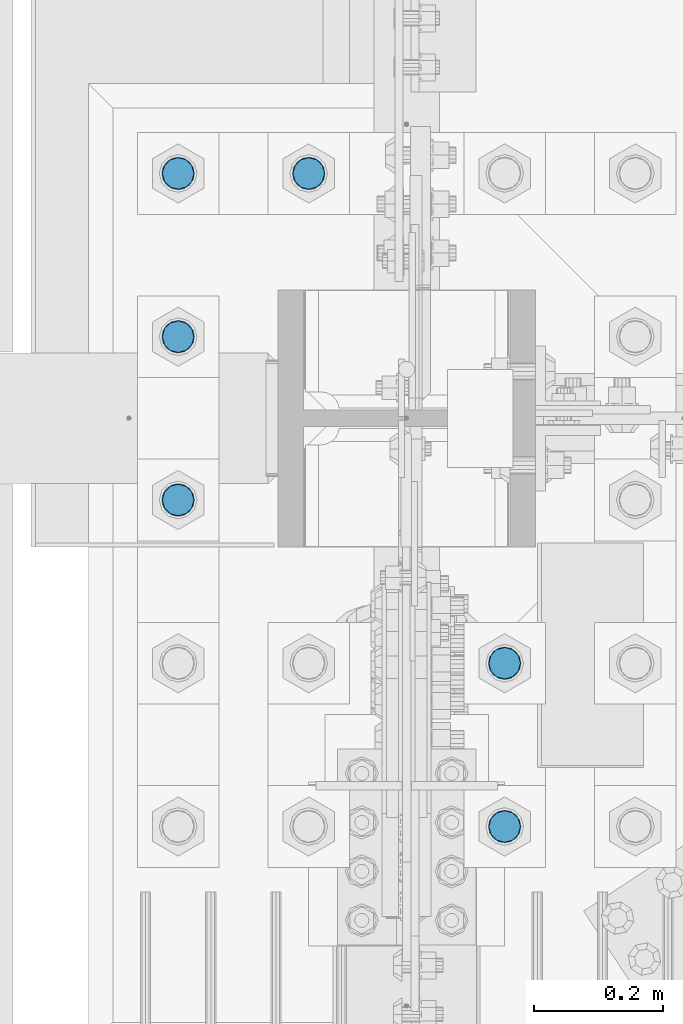
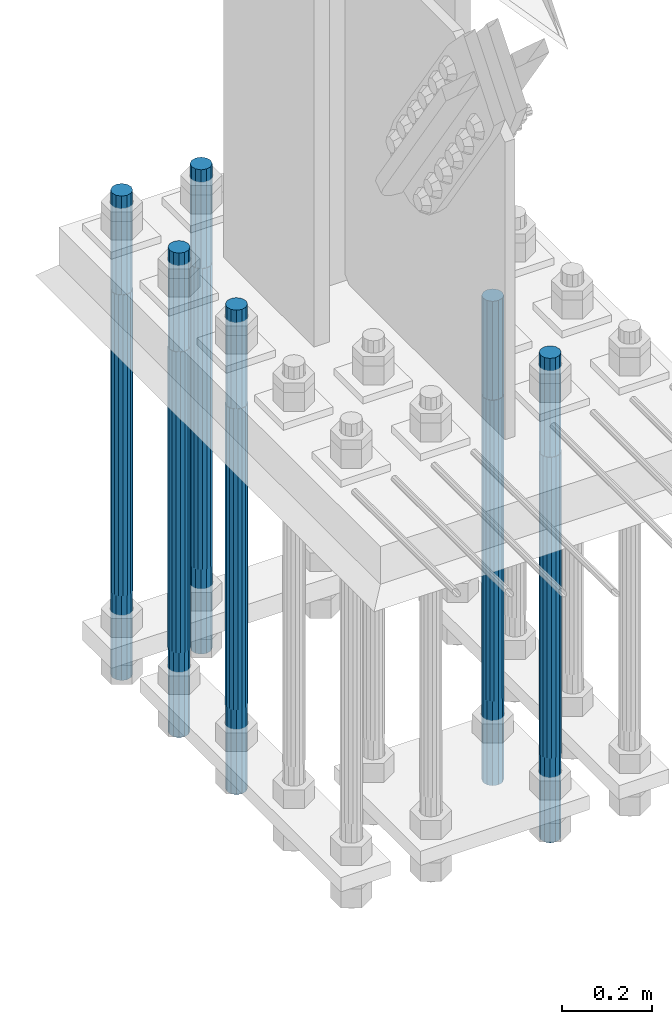
# One storey, part 1330 of 3843: 6 columns, 1 element without a shape of its own.
"""IFC2X3 building model written with IfcOpenShell, lengths in millimetres."""

from ifc_helpers import new_model, si_unit, frame, origin_with_axes, place, context, subcontext, project, spatial, faceted_brep, material, type_object, element, aggregate, save


model = new_model("IFC2X3")

# Units and contexts
model_context = context("Model", 3, precision=1e-05, world=origin_with_axes())
body_context = subcontext(model_context, "Body", "Model", "MODEL_VIEW")
ifc_project = project(units=[si_unit("LENGTHUNIT", "METRE", prefix="MILLI"), si_unit("AREAUNIT", "SQUARE_METRE"), si_unit("VOLUMEUNIT", "CUBIC_METRE"), si_unit("MASSUNIT", "GRAM", prefix="KILO"), si_unit("TIMEUNIT", "SECOND"), si_unit("PLANEANGLEUNIT", "RADIAN"), si_unit("SOLIDANGLEUNIT", "STERADIAN"), si_unit("THERMODYNAMICTEMPERATUREUNIT", "DEGREE_CELSIUS"), si_unit("LUMINOUSINTENSITYUNIT", "LUMEN")], contexts=[model_context])

# Site, building, storey
site_placement = place(None, origin_with_axes())
site = spatial("IfcSite", under=ifc_project, at=site_placement, CompositionType="ELEMENT")
building_placement = place(site_placement, origin_with_axes())
building = spatial("IfcBuilding", under=site, at=building_placement, Name="Undefined", CompositionType="ELEMENT")
storey_placement = place(building_placement, origin_with_axes())
storey = spatial("IfcBuildingStorey", under=building, at=storey_placement, Name="Undefined", CompositionType="ELEMENT", Elevation=0.0)

# Assembly, columns
assembly_placement = place(storey_placement, origin_with_axes())
assembly = element("IfcElementAssembly", 1, at=assembly_placement, inside=storey, Name="TEMPLATE", AssemblyPlace="NOTDEFINED", PredefinedType="RIGID_FRAME")
ifc_material = material(Name="Undefined/F1554-GR.55")
column_type = type_object("IfcColumnType", PredefinedType="NOTDEFINED")
column_1_placement = place(assembly_placement, frame((36728.4, 58280.3, 30022.8), z_axis=(1.0, 0.0, 0.0), x_axis=(0.0, 0.0, -1.0)))
column_1 = element("IfcColumn", 2, at=column_1_placement, type_object=column_type, material=ifc_material, Name="ANCHOR_ROD", context=body_context, shape_type="Brep", body=[
    faceted_brep([(-266.700000000001, -21.2176223927236, 12.25), (-266.700000000001, -12.25, 21.2176223927163), (-266.700000000001, 0.0, 24.5), (-266.700000000001, 12.25, 21.2176223927163), (-266.700000000001, 21.2176223927236, 12.25), (-266.700000000001, 24.5, 0.0), (-266.700000000001, 21.2176223927236, -12.25), (-266.700000000001, 12.25, -21.2176223927163), (-266.700000000001, 0.0, -24.5), (-266.700000000001, -12.25, -21.2176223927163), (-266.700000000001, -21.2176223927236, -12.25), (-266.700000000001, -24.5, 0.0), (0.0, 24.5000000000146, 0.0), (0.0, 21.2176223927381, -12.25), (0.0, 12.2500000000146, -21.2176223927163), (0.0, 1.45519152283669e-11, -24.5), (0.0, -12.2499999999854, -21.2176223927163), (0.0, -21.217622392709, -12.25), (0.0, -24.4999999999854, 0.0), (0.0, -21.217622392709, 12.25), (0.0, -12.2499999999854, 21.2176223927163), (0.0, 1.45519152283669e-11, 24.5), (0.0, 12.2500000000146, 21.2176223927163), (0.0, 21.2176223927381, 12.25), (0.0, -23.4665401257807, 9.72015918207035), (0.0, -17.9605122421344, 17.9605122421417), (0.0, -9.72015918207762, 23.466540125788), (0.0, 0.0, 25.4000000000015), (0.0, 9.72015918207762, 23.466540125788), (0.0, 17.9605122421344, 17.9605122421417), (0.0, 23.4665401257807, 9.72015918207035), (0.0, 25.3999996185303, 0.0), (0.0, 23.4665401257807, -9.72015918207035), (0.0, 17.9605122421344, -17.9605122421417), (0.0, 9.72015918207762, -23.466540125788), (0.0, 0.0, -25.4000000000015), (0.0, -9.72015918207762, -23.466540125788), (0.0, -17.9605122421344, -17.9605122421417), (0.0, -23.4665401257807, -9.72015918207035), (0.0, -25.3999996185303, 0.0), (812.799999999999, -25.4000000000015, 0.0), (812.799999999999, -23.466540125788, 9.72015918207398), (812.799999999999, -17.9605122421417, 17.9605122421381), (812.799999999999, -9.72015918207035, 23.466540125788), (812.799999999999, 0.0, 25.4000000000015), (812.799999999999, 9.72015918207035, 23.466540125788), (812.799999999999, 17.9605122421417, 17.9605122421381), (812.799999999999, 23.466540125788, 9.72015918207398), (812.799999999999, 25.4000000000015, 0.0), (812.799999999999, 23.466540125788, -9.72015918207398), (812.799999999999, 17.9605122421417, -17.9605122421381), (812.799999999999, 9.72015918207035, -23.466540125788), (812.799999999999, 0.0, -25.4000000000015), (812.799999999999, -9.72015918207035, -23.466540125788), (812.799999999999, -17.9605122421417, -17.9605122421381), (812.799999999999, -23.466540125788, -9.72015918207398), (812.799999999999, -12.25, 21.2176223927199), (812.799999999999, 0.0, 24.5), (812.799999999999, 12.25, 21.2176223927199), (812.799999999999, 21.2176223927163, 12.25), (812.799999999999, 24.5, 0.0), (812.799999999999, 21.2176223927163, -12.25), (812.799999999999, 12.25, -21.2176223927199), (812.799999999999, 0.0, -24.5), (812.799999999999, -12.25, -21.2176223927199), (812.799999999999, -21.2176223927163, -12.25), (812.799999999999, -24.5, 0.0), (812.799999999999, -21.2176223927163, 12.25), (1041.4, -12.25, -21.2176223927199), (1041.4, 0.0, -24.5), (1041.4, 12.25, -21.2176223927199), (1041.4, 21.2176223927163, -12.25), (1041.4, 24.5, 0.0), (1041.4, 21.2176223927163, 12.25), (1041.4, 12.25, 21.2176223927199), (1041.4, 0.0, 24.5), (1041.4, -12.25, 21.2176223927199), (1041.4, -21.2176223927163, 12.25), (1041.4, -24.5, 0.0), (1041.4, -21.2176223927163, -12.25)], [[[0, 1, 2, 3, 4, 5, 6, 7, 8, 9, 10, 11]], [[6, 5, 12, 13]], [[7, 6, 13, 14]], [[8, 7, 14, 15]], [[9, 8, 15, 16]], [[10, 9, 16, 17]], [[11, 10, 17, 18]], [[0, 11, 18, 19]], [[1, 0, 19, 20]], [[2, 1, 20, 21]], [[3, 2, 21, 22]], [[4, 3, 22, 23]], [[5, 4, 23, 12]], [[24, 25, 26, 27, 28, 29, 30, 31, 32, 33, 34, 35, 36, 37, 38, 39], [22, 21, 20, 19, 18, 17, 16, 15, 14, 13, 12, 23]], [[24, 39, 40, 41]], [[25, 24, 41, 42]], [[26, 25, 42, 43]], [[27, 26, 43, 44]], [[28, 27, 44, 45]], [[29, 28, 45, 46]], [[30, 29, 46, 47]], [[31, 30, 47, 48]], [[32, 31, 48, 49]], [[33, 32, 49, 50]], [[34, 33, 50, 51]], [[35, 34, 51, 52]], [[36, 35, 52, 53]], [[37, 36, 53, 54]], [[38, 37, 54, 55]], [[39, 38, 55, 40]], [[54, 53, 52, 51, 50, 49, 48, 47, 46, 45, 44, 43, 42, 41, 40, 55], [56, 57, 58, 59, 60, 61, 62, 63, 64, 65, 66, 67]], [[68, 69, 70, 71, 72, 73, 74, 75, 76, 77, 78, 79]], [[76, 75, 57, 56]], [[77, 76, 56, 67]], [[78, 77, 67, 66]], [[79, 78, 66, 65]], [[68, 79, 65, 64]], [[69, 68, 64, 63]], [[70, 69, 63, 62]], [[71, 70, 62, 61]], [[72, 71, 61, 60]], [[73, 72, 60, 59]], [[74, 73, 59, 58]], [[75, 74, 58, 57]]]),
])
column_2_placement = place(assembly_placement, frame((36728.4, 58534.3, 30022.8), z_axis=(1.0, 0.0, 0.0), x_axis=(0.0, 0.0, -1.0)))
column_2 = element("IfcColumn", 3, at=column_2_placement, type_object=column_type, material=ifc_material, Name="ANCHOR_ROD", context=body_context, shape_type="Brep", body=[
    faceted_brep([(-266.700000000001, -21.2176223927236, 12.25), (-266.700000000001, -12.25, 21.2176223927163), (-266.700000000001, 0.0, 24.5), (-266.700000000001, 12.25, 21.2176223927163), (-266.700000000001, 21.2176223927236, 12.25), (-266.700000000001, 24.5, 0.0), (-266.700000000001, 21.2176223927236, -12.25), (-266.700000000001, 12.25, -21.2176223927163), (-266.700000000001, 0.0, -24.5), (-266.700000000001, -12.25, -21.2176223927163), (-266.700000000001, -21.2176223927236, -12.25), (-266.700000000001, -24.5, 0.0), (0.0, 24.5000000000146, 0.0), (0.0, 21.2176223927381, -12.25), (0.0, 12.2500000000146, -21.2176223927163), (0.0, 1.45519152283669e-11, -24.5), (0.0, -12.2499999999854, -21.2176223927163), (0.0, -21.217622392709, -12.25), (0.0, -24.4999999999854, 0.0), (0.0, -21.217622392709, 12.25), (0.0, -12.2499999999854, 21.2176223927163), (0.0, 1.45519152283669e-11, 24.5), (0.0, 12.2500000000146, 21.2176223927163), (0.0, 21.2176223927381, 12.25), (0.0, -23.4665401257807, 9.72015918207035), (0.0, -17.9605122421344, 17.9605122421417), (0.0, -9.72015918207762, 23.466540125788), (0.0, 0.0, 25.4000000000015), (0.0, 9.72015918207762, 23.466540125788), (0.0, 17.9605122421344, 17.9605122421417), (0.0, 23.4665401257807, 9.72015918207035), (0.0, 25.3999996185303, 0.0), (0.0, 23.4665401257807, -9.72015918207035), (0.0, 17.9605122421344, -17.9605122421417), (0.0, 9.72015918207762, -23.466540125788), (0.0, 0.0, -25.4000000000015), (0.0, -9.72015918207762, -23.466540125788), (0.0, -17.9605122421344, -17.9605122421417), (0.0, -23.4665401257807, -9.72015918207035), (0.0, -25.3999996185303, 0.0), (812.799999999999, -25.4000000000015, 0.0), (812.799999999999, -23.466540125788, 9.72015918207398), (812.799999999999, -17.9605122421417, 17.9605122421381), (812.799999999999, -9.72015918207035, 23.466540125788), (812.799999999999, 0.0, 25.4000000000015), (812.799999999999, 9.72015918207035, 23.466540125788), (812.799999999999, 17.9605122421417, 17.9605122421381), (812.799999999999, 23.466540125788, 9.72015918207398), (812.799999999999, 25.4000000000015, 0.0), (812.799999999999, 23.466540125788, -9.72015918207398), (812.799999999999, 17.9605122421417, -17.9605122421381), (812.799999999999, 9.72015918207035, -23.466540125788), (812.799999999999, 0.0, -25.4000000000015), (812.799999999999, -9.72015918207035, -23.466540125788), (812.799999999999, -17.9605122421417, -17.9605122421381), (812.799999999999, -23.466540125788, -9.72015918207398), (812.799999999999, -12.25, 21.2176223927199), (812.799999999999, 0.0, 24.5), (812.799999999999, 12.25, 21.2176223927199), (812.799999999999, 21.2176223927163, 12.25), (812.799999999999, 24.5, 0.0), (812.799999999999, 21.2176223927163, -12.25), (812.799999999999, 12.25, -21.2176223927199), (812.799999999999, 0.0, -24.5), (812.799999999999, -12.25, -21.2176223927199), (812.799999999999, -21.2176223927163, -12.25), (812.799999999999, -24.5, 0.0), (812.799999999999, -21.2176223927163, 12.25), (1041.4, -12.25, -21.2176223927199), (1041.4, 0.0, -24.5), (1041.4, 12.25, -21.2176223927199), (1041.4, 21.2176223927163, -12.25), (1041.4, 24.5, 0.0), (1041.4, 21.2176223927163, 12.25), (1041.4, 12.25, 21.2176223927199), (1041.4, 0.0, 24.5), (1041.4, -12.25, 21.2176223927199), (1041.4, -21.2176223927163, 12.25), (1041.4, -24.5, 0.0), (1041.4, -21.2176223927163, -12.25)], [[[0, 1, 2, 3, 4, 5, 6, 7, 8, 9, 10, 11]], [[6, 5, 12, 13]], [[7, 6, 13, 14]], [[8, 7, 14, 15]], [[9, 8, 15, 16]], [[10, 9, 16, 17]], [[11, 10, 17, 18]], [[0, 11, 18, 19]], [[1, 0, 19, 20]], [[2, 1, 20, 21]], [[3, 2, 21, 22]], [[4, 3, 22, 23]], [[5, 4, 23, 12]], [[24, 25, 26, 27, 28, 29, 30, 31, 32, 33, 34, 35, 36, 37, 38, 39], [22, 21, 20, 19, 18, 17, 16, 15, 14, 13, 12, 23]], [[24, 39, 40, 41]], [[25, 24, 41, 42]], [[26, 25, 42, 43]], [[27, 26, 43, 44]], [[28, 27, 44, 45]], [[29, 28, 45, 46]], [[30, 29, 46, 47]], [[31, 30, 47, 48]], [[32, 31, 48, 49]], [[33, 32, 49, 50]], [[34, 33, 50, 51]], [[35, 34, 51, 52]], [[36, 35, 52, 53]], [[37, 36, 53, 54]], [[38, 37, 54, 55]], [[39, 38, 55, 40]], [[54, 53, 52, 51, 50, 49, 48, 47, 46, 45, 44, 43, 42, 41, 40, 55], [56, 57, 58, 59, 60, 61, 62, 63, 64, 65, 66, 67]], [[68, 69, 70, 71, 72, 73, 74, 75, 76, 77, 78, 79]], [[76, 75, 57, 56]], [[77, 76, 56, 67]], [[78, 77, 67, 66]], [[79, 78, 66, 65]], [[68, 79, 65, 64]], [[69, 68, 64, 63]], [[70, 69, 63, 62]], [[71, 70, 62, 61]], [[72, 71, 61, 60]], [[73, 72, 60, 59]], [[74, 73, 59, 58]], [[75, 74, 58, 57]]]),
])
column_3_placement = place(assembly_placement, frame((36423.6, 59296.3, 30022.8), z_axis=(-1.0, 0.0, 0.0), x_axis=(0.0, 0.0, -1.0)))
column_3 = element("IfcColumn", 4, at=column_3_placement, type_object=column_type, material=ifc_material, Name="ANCHOR_ROD", context=body_context, shape_type="Brep", body=[
    faceted_brep([(-266.700000000001, -21.2176223927236, 12.25), (-266.700000000001, -12.25, 21.2176223927163), (-266.700000000001, 0.0, 24.5), (-266.700000000001, 12.25, 21.2176223927163), (-266.700000000001, 21.2176223927236, 12.25), (-266.700000000001, 24.5, 0.0), (-266.700000000001, 21.2176223927236, -12.25), (-266.700000000001, 12.25, -21.2176223927163), (-266.700000000001, 0.0, -24.5), (-266.700000000001, -12.25, -21.2176223927163), (-266.700000000001, -21.2176223927236, -12.25), (-266.700000000001, -24.5, 0.0), (0.0, 24.5000000000146, 0.0), (0.0, 21.2176223927381, -12.25), (0.0, 12.2500000000146, -21.2176223927163), (0.0, 1.45519152283669e-11, -24.5), (0.0, -12.2499999999854, -21.2176223927163), (0.0, -21.217622392709, -12.25), (0.0, -24.4999999999854, 0.0), (0.0, -21.217622392709, 12.25), (0.0, -12.2499999999854, 21.2176223927163), (0.0, 1.45519152283669e-11, 24.5), (0.0, 12.2500000000146, 21.2176223927163), (0.0, 21.2176223927381, 12.25), (0.0, -23.4665401257807, 9.72015918207035), (0.0, -17.9605122421344, 17.9605122421417), (0.0, -9.72015918207762, 23.466540125788), (0.0, 0.0, 25.4000000000015), (0.0, 9.72015918207762, 23.466540125788), (0.0, 17.9605122421344, 17.9605122421417), (0.0, 23.4665401257807, 9.72015918207035), (0.0, 25.3999996185303, 0.0), (0.0, 23.4665401257807, -9.72015918207035), (0.0, 17.9605122421344, -17.9605122421417), (0.0, 9.72015918207762, -23.466540125788), (0.0, 0.0, -25.4000000000015), (0.0, -9.72015918207762, -23.466540125788), (0.0, -17.9605122421344, -17.9605122421417), (0.0, -23.4665401257807, -9.72015918207035), (0.0, -25.3999996185303, 0.0), (812.799999999999, -25.4000000000015, 0.0), (812.799999999999, -23.466540125788, 9.72015918207398), (812.799999999999, -17.9605122421417, 17.9605122421381), (812.799999999999, -9.72015918207035, 23.466540125788), (812.799999999999, 0.0, 25.4000000000015), (812.799999999999, 9.72015918207035, 23.466540125788), (812.799999999999, 17.9605122421417, 17.9605122421381), (812.799999999999, 23.466540125788, 9.72015918207398), (812.799999999999, 25.4000000000015, 0.0), (812.799999999999, 23.466540125788, -9.72015918207398), (812.799999999999, 17.9605122421417, -17.9605122421381), (812.799999999999, 9.72015918207035, -23.466540125788), (812.799999999999, 0.0, -25.4000000000015), (812.799999999999, -9.72015918207035, -23.466540125788), (812.799999999999, -17.9605122421417, -17.9605122421381), (812.799999999999, -23.466540125788, -9.72015918207398), (812.799999999999, -12.25, 21.2176223927199), (812.799999999999, 0.0, 24.5), (812.799999999999, 12.25, 21.2176223927199), (812.799999999999, 21.2176223927163, 12.25), (812.799999999999, 24.5, 0.0), (812.799999999999, 21.2176223927163, -12.25), (812.799999999999, 12.25, -21.2176223927199), (812.799999999999, 0.0, -24.5), (812.799999999999, -12.25, -21.2176223927199), (812.799999999999, -21.2176223927163, -12.25), (812.799999999999, -24.5, 0.0), (812.799999999999, -21.2176223927163, 12.25), (1041.4, -12.25, -21.2176223927199), (1041.4, 0.0, -24.5), (1041.4, 12.25, -21.2176223927199), (1041.4, 21.2176223927163, -12.25), (1041.4, 24.5, 0.0), (1041.4, 21.2176223927163, 12.25), (1041.4, 12.25, 21.2176223927199), (1041.4, 0.0, 24.5), (1041.4, -12.25, 21.2176223927199), (1041.4, -21.2176223927163, 12.25), (1041.4, -24.5, 0.0), (1041.4, -21.2176223927163, -12.25)], [[[0, 1, 2, 3, 4, 5, 6, 7, 8, 9, 10, 11]], [[6, 5, 12, 13]], [[7, 6, 13, 14]], [[8, 7, 14, 15]], [[9, 8, 15, 16]], [[10, 9, 16, 17]], [[11, 10, 17, 18]], [[0, 11, 18, 19]], [[1, 0, 19, 20]], [[2, 1, 20, 21]], [[3, 2, 21, 22]], [[4, 3, 22, 23]], [[5, 4, 23, 12]], [[24, 25, 26, 27, 28, 29, 30, 31, 32, 33, 34, 35, 36, 37, 38, 39], [22, 21, 20, 19, 18, 17, 16, 15, 14, 13, 12, 23]], [[24, 39, 40, 41]], [[25, 24, 41, 42]], [[26, 25, 42, 43]], [[27, 26, 43, 44]], [[28, 27, 44, 45]], [[29, 28, 45, 46]], [[30, 29, 46, 47]], [[31, 30, 47, 48]], [[32, 31, 48, 49]], [[33, 32, 49, 50]], [[34, 33, 50, 51]], [[35, 34, 51, 52]], [[36, 35, 52, 53]], [[37, 36, 53, 54]], [[38, 37, 54, 55]], [[39, 38, 55, 40]], [[54, 53, 52, 51, 50, 49, 48, 47, 46, 45, 44, 43, 42, 41, 40, 55], [56, 57, 58, 59, 60, 61, 62, 63, 64, 65, 66, 67]], [[68, 69, 70, 71, 72, 73, 74, 75, 76, 77, 78, 79]], [[76, 75, 57, 56]], [[77, 76, 56, 67]], [[78, 77, 67, 66]], [[79, 78, 66, 65]], [[68, 79, 65, 64]], [[69, 68, 64, 63]], [[70, 69, 63, 62]], [[71, 70, 62, 61]], [[72, 71, 61, 60]], [[73, 72, 60, 59]], [[74, 73, 59, 58]], [[75, 74, 58, 57]]]),
])
column_4_placement = place(assembly_placement, frame((36220.4, 58788.3, 30022.8), z_axis=(1.0, 0.0, 0.0), x_axis=(0.0, 0.0, -1.0)))
column_4 = element("IfcColumn", 5, at=column_4_placement, type_object=column_type, material=ifc_material, Name="ANCHOR_ROD", context=body_context, shape_type="Brep", body=[
    faceted_brep([(-266.700000000001, -21.2176223927236, 12.25), (-266.700000000001, -12.25, 21.2176223927163), (-266.700000000001, 0.0, 24.5), (-266.700000000001, 12.25, 21.2176223927163), (-266.700000000001, 21.2176223927236, 12.25), (-266.700000000001, 24.5, 0.0), (-266.700000000001, 21.2176223927236, -12.25), (-266.700000000001, 12.25, -21.2176223927163), (-266.700000000001, 0.0, -24.5), (-266.700000000001, -12.25, -21.2176223927163), (-266.700000000001, -21.2176223927236, -12.25), (-266.700000000001, -24.5, 0.0), (0.0, 24.5000000000146, 0.0), (0.0, 21.2176223927381, -12.25), (0.0, 12.2500000000146, -21.2176223927163), (0.0, 1.45519152283669e-11, -24.5), (0.0, -12.2499999999854, -21.2176223927163), (0.0, -21.217622392709, -12.25), (0.0, -24.4999999999854, 0.0), (0.0, -21.217622392709, 12.25), (0.0, -12.2499999999854, 21.2176223927163), (0.0, 1.45519152283669e-11, 24.5), (0.0, 12.2500000000146, 21.2176223927163), (0.0, 21.2176223927381, 12.25), (0.0, -23.4665401257807, 9.72015918207035), (0.0, -17.9605122421344, 17.9605122421417), (0.0, -9.72015918207762, 23.466540125788), (0.0, 0.0, 25.4000000000015), (0.0, 9.72015918207762, 23.466540125788), (0.0, 17.9605122421344, 17.9605122421417), (0.0, 23.4665401257807, 9.72015918207035), (0.0, 25.3999996185303, 0.0), (0.0, 23.4665401257807, -9.72015918207035), (0.0, 17.9605122421344, -17.9605122421417), (0.0, 9.72015918207762, -23.466540125788), (0.0, 0.0, -25.4000000000015), (0.0, -9.72015918207762, -23.466540125788), (0.0, -17.9605122421344, -17.9605122421417), (0.0, -23.4665401257807, -9.72015918207035), (0.0, -25.3999996185303, 0.0), (812.799999999999, -25.4000000000015, 0.0), (812.799999999999, -23.466540125788, 9.72015918207398), (812.799999999999, -17.9605122421417, 17.9605122421381), (812.799999999999, -9.72015918207035, 23.466540125788), (812.799999999999, 0.0, 25.4000000000015), (812.799999999999, 9.72015918207035, 23.466540125788), (812.799999999999, 17.9605122421417, 17.9605122421381), (812.799999999999, 23.466540125788, 9.72015918207398), (812.799999999999, 25.4000000000015, 0.0), (812.799999999999, 23.466540125788, -9.72015918207398), (812.799999999999, 17.9605122421417, -17.9605122421381), (812.799999999999, 9.72015918207035, -23.466540125788), (812.799999999999, 0.0, -25.4000000000015), (812.799999999999, -9.72015918207035, -23.466540125788), (812.799999999999, -17.9605122421417, -17.9605122421381), (812.799999999999, -23.466540125788, -9.72015918207398), (812.799999999999, -12.25, 21.2176223927199), (812.799999999999, 0.0, 24.5), (812.799999999999, 12.25, 21.2176223927199), (812.799999999999, 21.2176223927163, 12.25), (812.799999999999, 24.5, 0.0), (812.799999999999, 21.2176223927163, -12.25), (812.799999999999, 12.25, -21.2176223927199), (812.799999999999, 0.0, -24.5), (812.799999999999, -12.25, -21.2176223927199), (812.799999999999, -21.2176223927163, -12.25), (812.799999999999, -24.5, 0.0), (812.799999999999, -21.2176223927163, 12.25), (1041.4, -12.25, -21.2176223927199), (1041.4, 0.0, -24.5), (1041.4, 12.25, -21.2176223927199), (1041.4, 21.2176223927163, -12.25), (1041.4, 24.5, 0.0), (1041.4, 21.2176223927163, 12.25), (1041.4, 12.25, 21.2176223927199), (1041.4, 0.0, 24.5), (1041.4, -12.25, 21.2176223927199), (1041.4, -21.2176223927163, 12.25), (1041.4, -24.5, 0.0), (1041.4, -21.2176223927163, -12.25)], [[[0, 1, 2, 3, 4, 5, 6, 7, 8, 9, 10, 11]], [[6, 5, 12, 13]], [[7, 6, 13, 14]], [[8, 7, 14, 15]], [[9, 8, 15, 16]], [[10, 9, 16, 17]], [[11, 10, 17, 18]], [[0, 11, 18, 19]], [[1, 0, 19, 20]], [[2, 1, 20, 21]], [[3, 2, 21, 22]], [[4, 3, 22, 23]], [[5, 4, 23, 12]], [[24, 25, 26, 27, 28, 29, 30, 31, 32, 33, 34, 35, 36, 37, 38, 39], [22, 21, 20, 19, 18, 17, 16, 15, 14, 13, 12, 23]], [[24, 39, 40, 41]], [[25, 24, 41, 42]], [[26, 25, 42, 43]], [[27, 26, 43, 44]], [[28, 27, 44, 45]], [[29, 28, 45, 46]], [[30, 29, 46, 47]], [[31, 30, 47, 48]], [[32, 31, 48, 49]], [[33, 32, 49, 50]], [[34, 33, 50, 51]], [[35, 34, 51, 52]], [[36, 35, 52, 53]], [[37, 36, 53, 54]], [[38, 37, 54, 55]], [[39, 38, 55, 40]], [[54, 53, 52, 51, 50, 49, 48, 47, 46, 45, 44, 43, 42, 41, 40, 55], [56, 57, 58, 59, 60, 61, 62, 63, 64, 65, 66, 67]], [[68, 69, 70, 71, 72, 73, 74, 75, 76, 77, 78, 79]], [[76, 75, 57, 56]], [[77, 76, 56, 67]], [[78, 77, 67, 66]], [[79, 78, 66, 65]], [[68, 79, 65, 64]], [[69, 68, 64, 63]], [[70, 69, 63, 62]], [[71, 70, 62, 61]], [[72, 71, 61, 60]], [[73, 72, 60, 59]], [[74, 73, 59, 58]], [[75, 74, 58, 57]]]),
])
column_5_placement = place(assembly_placement, frame((36220.4, 59042.3, 30022.8), z_axis=(-1.0, 0.0, 0.0), x_axis=(0.0, 0.0, -1.0)))
column_5 = element("IfcColumn", 6, at=column_5_placement, type_object=column_type, material=ifc_material, Name="ANCHOR_ROD", context=body_context, shape_type="Brep", body=[
    faceted_brep([(-266.700000000001, -21.2176223927236, 12.25), (-266.700000000001, -12.25, 21.2176223927163), (-266.700000000001, 0.0, 24.5), (-266.700000000001, 12.25, 21.2176223927163), (-266.700000000001, 21.2176223927236, 12.25), (-266.700000000001, 24.5, 0.0), (-266.700000000001, 21.2176223927236, -12.25), (-266.700000000001, 12.25, -21.2176223927163), (-266.700000000001, 0.0, -24.5), (-266.700000000001, -12.25, -21.2176223927163), (-266.700000000001, -21.2176223927236, -12.25), (-266.700000000001, -24.5, 0.0), (0.0, 24.5000000000146, 0.0), (0.0, 21.2176223927381, -12.25), (0.0, 12.2500000000146, -21.2176223927163), (0.0, 1.45519152283669e-11, -24.5), (0.0, -12.2499999999854, -21.2176223927163), (0.0, -21.217622392709, -12.25), (0.0, -24.4999999999854, 0.0), (0.0, -21.217622392709, 12.25), (0.0, -12.2499999999854, 21.2176223927163), (0.0, 1.45519152283669e-11, 24.5), (0.0, 12.2500000000146, 21.2176223927163), (0.0, 21.2176223927381, 12.25), (0.0, -23.4665401257807, 9.72015918207035), (0.0, -17.9605122421344, 17.9605122421417), (0.0, -9.72015918207762, 23.466540125788), (0.0, 0.0, 25.4000000000015), (0.0, 9.72015918207762, 23.466540125788), (0.0, 17.9605122421344, 17.9605122421417), (0.0, 23.4665401257807, 9.72015918207035), (0.0, 25.3999996185303, 0.0), (0.0, 23.4665401257807, -9.72015918207035), (0.0, 17.9605122421344, -17.9605122421417), (0.0, 9.72015918207762, -23.466540125788), (0.0, 0.0, -25.4000000000015), (0.0, -9.72015918207762, -23.466540125788), (0.0, -17.9605122421344, -17.9605122421417), (0.0, -23.4665401257807, -9.72015918207035), (0.0, -25.3999996185303, 0.0), (812.799999999999, -25.4000000000015, 0.0), (812.799999999999, -23.466540125788, 9.72015918207398), (812.799999999999, -17.9605122421417, 17.9605122421381), (812.799999999999, -9.72015918207035, 23.466540125788), (812.799999999999, 0.0, 25.4000000000015), (812.799999999999, 9.72015918207035, 23.466540125788), (812.799999999999, 17.9605122421417, 17.9605122421381), (812.799999999999, 23.466540125788, 9.72015918207398), (812.799999999999, 25.4000000000015, 0.0), (812.799999999999, 23.466540125788, -9.72015918207398), (812.799999999999, 17.9605122421417, -17.9605122421381), (812.799999999999, 9.72015918207035, -23.466540125788), (812.799999999999, 0.0, -25.4000000000015), (812.799999999999, -9.72015918207035, -23.466540125788), (812.799999999999, -17.9605122421417, -17.9605122421381), (812.799999999999, -23.466540125788, -9.72015918207398), (812.799999999999, -12.25, 21.2176223927199), (812.799999999999, 0.0, 24.5), (812.799999999999, 12.25, 21.2176223927199), (812.799999999999, 21.2176223927163, 12.25), (812.799999999999, 24.5, 0.0), (812.799999999999, 21.2176223927163, -12.25), (812.799999999999, 12.25, -21.2176223927199), (812.799999999999, 0.0, -24.5), (812.799999999999, -12.25, -21.2176223927199), (812.799999999999, -21.2176223927163, -12.25), (812.799999999999, -24.5, 0.0), (812.799999999999, -21.2176223927163, 12.25), (1041.4, -12.25, -21.2176223927199), (1041.4, 0.0, -24.5), (1041.4, 12.25, -21.2176223927199), (1041.4, 21.2176223927163, -12.25), (1041.4, 24.5, 0.0), (1041.4, 21.2176223927163, 12.25), (1041.4, 12.25, 21.2176223927199), (1041.4, 0.0, 24.5), (1041.4, -12.25, 21.2176223927199), (1041.4, -21.2176223927163, 12.25), (1041.4, -24.5, 0.0), (1041.4, -21.2176223927163, -12.25)], [[[0, 1, 2, 3, 4, 5, 6, 7, 8, 9, 10, 11]], [[6, 5, 12, 13]], [[7, 6, 13, 14]], [[8, 7, 14, 15]], [[9, 8, 15, 16]], [[10, 9, 16, 17]], [[11, 10, 17, 18]], [[0, 11, 18, 19]], [[1, 0, 19, 20]], [[2, 1, 20, 21]], [[3, 2, 21, 22]], [[4, 3, 22, 23]], [[5, 4, 23, 12]], [[24, 25, 26, 27, 28, 29, 30, 31, 32, 33, 34, 35, 36, 37, 38, 39], [22, 21, 20, 19, 18, 17, 16, 15, 14, 13, 12, 23]], [[24, 39, 40, 41]], [[25, 24, 41, 42]], [[26, 25, 42, 43]], [[27, 26, 43, 44]], [[28, 27, 44, 45]], [[29, 28, 45, 46]], [[30, 29, 46, 47]], [[31, 30, 47, 48]], [[32, 31, 48, 49]], [[33, 32, 49, 50]], [[34, 33, 50, 51]], [[35, 34, 51, 52]], [[36, 35, 52, 53]], [[37, 36, 53, 54]], [[38, 37, 54, 55]], [[39, 38, 55, 40]], [[54, 53, 52, 51, 50, 49, 48, 47, 46, 45, 44, 43, 42, 41, 40, 55], [56, 57, 58, 59, 60, 61, 62, 63, 64, 65, 66, 67]], [[68, 69, 70, 71, 72, 73, 74, 75, 76, 77, 78, 79]], [[76, 75, 57, 56]], [[77, 76, 56, 67]], [[78, 77, 67, 66]], [[79, 78, 66, 65]], [[68, 79, 65, 64]], [[69, 68, 64, 63]], [[70, 69, 63, 62]], [[71, 70, 62, 61]], [[72, 71, 61, 60]], [[73, 72, 60, 59]], [[74, 73, 59, 58]], [[75, 74, 58, 57]]]),
])
column_6_placement = place(assembly_placement, frame((36220.4, 59296.3, 30022.8), z_axis=(-1.0, 0.0, 0.0), x_axis=(0.0, 0.0, -1.0)))
column_6 = element("IfcColumn", 7, at=column_6_placement, type_object=column_type, material=ifc_material, Name="ANCHOR_ROD", context=body_context, shape_type="Brep", body=[
    faceted_brep([(-266.700000000001, -21.2176223927236, 12.25), (-266.700000000001, -12.25, 21.2176223927163), (-266.700000000001, 0.0, 24.5), (-266.700000000001, 12.25, 21.2176223927163), (-266.700000000001, 21.2176223927236, 12.25), (-266.700000000001, 24.5, 0.0), (-266.700000000001, 21.2176223927236, -12.25), (-266.700000000001, 12.25, -21.2176223927163), (-266.700000000001, 0.0, -24.5), (-266.700000000001, -12.25, -21.2176223927163), (-266.700000000001, -21.2176223927236, -12.25), (-266.700000000001, -24.5, 0.0), (0.0, 24.5000000000146, 0.0), (0.0, 21.2176223927381, -12.25), (0.0, 12.2500000000146, -21.2176223927163), (0.0, 1.45519152283669e-11, -24.5), (0.0, -12.2499999999854, -21.2176223927163), (0.0, -21.217622392709, -12.25), (0.0, -24.4999999999854, 0.0), (0.0, -21.217622392709, 12.25), (0.0, -12.2499999999854, 21.2176223927163), (0.0, 1.45519152283669e-11, 24.5), (0.0, 12.2500000000146, 21.2176223927163), (0.0, 21.2176223927381, 12.25), (0.0, -23.4665401257807, 9.72015918207035), (0.0, -17.9605122421344, 17.9605122421417), (0.0, -9.72015918207762, 23.466540125788), (0.0, 0.0, 25.4000000000015), (0.0, 9.72015918207762, 23.466540125788), (0.0, 17.9605122421344, 17.9605122421417), (0.0, 23.4665401257807, 9.72015918207035), (0.0, 25.3999996185303, 0.0), (0.0, 23.4665401257807, -9.72015918207035), (0.0, 17.9605122421344, -17.9605122421417), (0.0, 9.72015918207762, -23.466540125788), (0.0, 0.0, -25.4000000000015), (0.0, -9.72015918207762, -23.466540125788), (0.0, -17.9605122421344, -17.9605122421417), (0.0, -23.4665401257807, -9.72015918207035), (0.0, -25.3999996185303, 0.0), (812.799999999999, -25.4000000000015, 0.0), (812.799999999999, -23.466540125788, 9.72015918207398), (812.799999999999, -17.9605122421417, 17.9605122421381), (812.799999999999, -9.72015918207035, 23.466540125788), (812.799999999999, 0.0, 25.4000000000015), (812.799999999999, 9.72015918207035, 23.466540125788), (812.799999999999, 17.9605122421417, 17.9605122421381), (812.799999999999, 23.466540125788, 9.72015918207398), (812.799999999999, 25.4000000000015, 0.0), (812.799999999999, 23.466540125788, -9.72015918207398), (812.799999999999, 17.9605122421417, -17.9605122421381), (812.799999999999, 9.72015918207035, -23.466540125788), (812.799999999999, 0.0, -25.4000000000015), (812.799999999999, -9.72015918207035, -23.466540125788), (812.799999999999, -17.9605122421417, -17.9605122421381), (812.799999999999, -23.466540125788, -9.72015918207398), (812.799999999999, -12.25, 21.2176223927199), (812.799999999999, 0.0, 24.5), (812.799999999999, 12.25, 21.2176223927199), (812.799999999999, 21.2176223927163, 12.25), (812.799999999999, 24.5, 0.0), (812.799999999999, 21.2176223927163, -12.25), (812.799999999999, 12.25, -21.2176223927199), (812.799999999999, 0.0, -24.5), (812.799999999999, -12.25, -21.2176223927199), (812.799999999999, -21.2176223927163, -12.25), (812.799999999999, -24.5, 0.0), (812.799999999999, -21.2176223927163, 12.25), (1041.4, -12.25, -21.2176223927199), (1041.4, 0.0, -24.5), (1041.4, 12.25, -21.2176223927199), (1041.4, 21.2176223927163, -12.25), (1041.4, 24.5, 0.0), (1041.4, 21.2176223927163, 12.25), (1041.4, 12.25, 21.2176223927199), (1041.4, 0.0, 24.5), (1041.4, -12.25, 21.2176223927199), (1041.4, -21.2176223927163, 12.25), (1041.4, -24.5, 0.0), (1041.4, -21.2176223927163, -12.25)], [[[0, 1, 2, 3, 4, 5, 6, 7, 8, 9, 10, 11]], [[6, 5, 12, 13]], [[7, 6, 13, 14]], [[8, 7, 14, 15]], [[9, 8, 15, 16]], [[10, 9, 16, 17]], [[11, 10, 17, 18]], [[0, 11, 18, 19]], [[1, 0, 19, 20]], [[2, 1, 20, 21]], [[3, 2, 21, 22]], [[4, 3, 22, 23]], [[5, 4, 23, 12]], [[24, 25, 26, 27, 28, 29, 30, 31, 32, 33, 34, 35, 36, 37, 38, 39], [22, 21, 20, 19, 18, 17, 16, 15, 14, 13, 12, 23]], [[24, 39, 40, 41]], [[25, 24, 41, 42]], [[26, 25, 42, 43]], [[27, 26, 43, 44]], [[28, 27, 44, 45]], [[29, 28, 45, 46]], [[30, 29, 46, 47]], [[31, 30, 47, 48]], [[32, 31, 48, 49]], [[33, 32, 49, 50]], [[34, 33, 50, 51]], [[35, 34, 51, 52]], [[36, 35, 52, 53]], [[37, 36, 53, 54]], [[38, 37, 54, 55]], [[39, 38, 55, 40]], [[54, 53, 52, 51, 50, 49, 48, 47, 46, 45, 44, 43, 42, 41, 40, 55], [56, 57, 58, 59, 60, 61, 62, 63, 64, 65, 66, 67]], [[68, 69, 70, 71, 72, 73, 74, 75, 76, 77, 78, 79]], [[76, 75, 57, 56]], [[77, 76, 56, 67]], [[78, 77, 67, 66]], [[79, 78, 66, 65]], [[68, 79, 65, 64]], [[69, 68, 64, 63]], [[70, 69, 63, 62]], [[71, 70, 62, 61]], [[72, 71, 61, 60]], [[73, 72, 60, 59]], [[74, 73, 59, 58]], [[75, 74, 58, 57]]]),
])
aggregate(assembly, [column_1, column_2, column_3, column_4, column_5, column_6])

save(model, "model.ifc")
